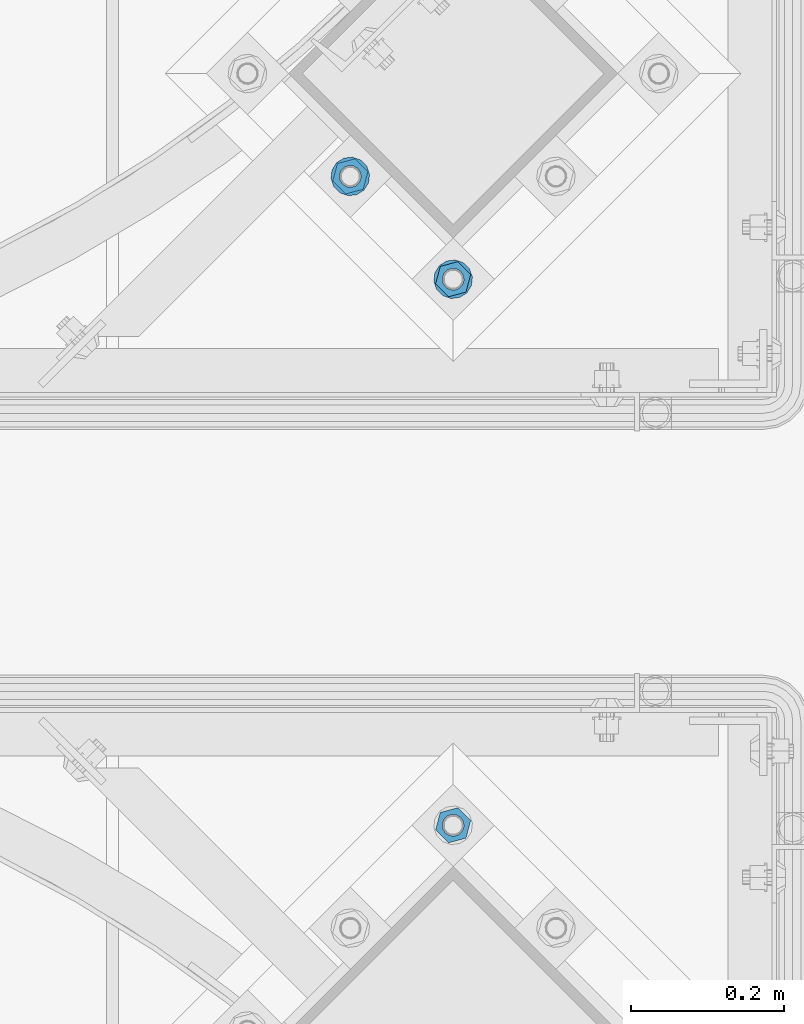
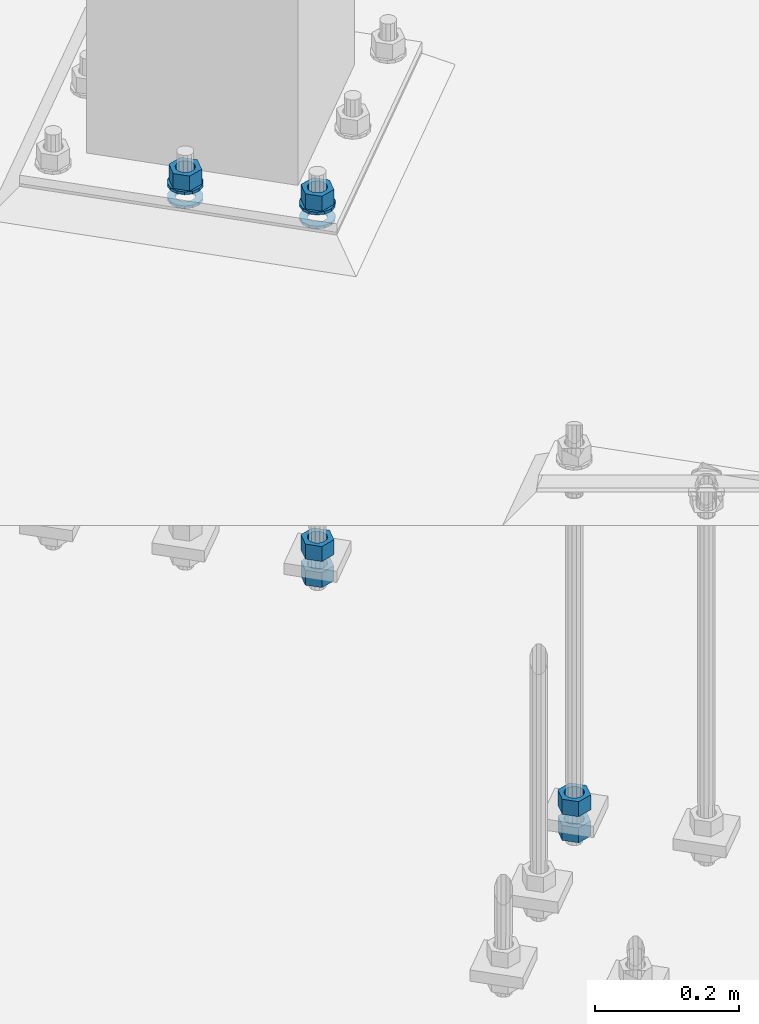
# One storey, part 881 of 1876: 10 columns, 2 elements without a shape of their own.
"""IFC2X3 building model written with IfcOpenShell, lengths in millimetres."""

import ifcopenshell
import ifcopenshell.guid

model = None  # the IFC model being written
_history = None  # IfcOwnerHistory: only IFC2X3 demands one
_inside = {}  # id of a spatial element -> (the spatial element, [elements in it])
_under = {}  # id of a project, library or spatial element -> (it, [spatial elements below it])
_declared = {}  # id of a project -> (the project, [libraries it declares])
_typed = {}  # id of a type object -> (the type object, [elements of that type])
_made_of = {}  # id of a material, layer set ... -> (it, [elements and type objects made of it])


def new_model(schema):
    """Start an empty IFC model of exactly this schema.

    Asked for "IFC4X3", IfcOpenShell would pick the latest addendum, in which some entities
    have other attributes; the version numbers below select the first issue.
    IFC2X3 requires an IfcOwnerHistory on every rooted entity: one is made here for all.
    """
    global model, _history
    if schema == "IFC4X3":
        model = ifcopenshell.file(schema_version=(4, 3, 0, 0))
    else:
        model = ifcopenshell.file(schema=schema)
    _inside.clear()
    _under.clear()
    _declared.clear()
    _typed.clear()
    _made_of.clear()
    _history = None
    if model.schema == "IFC2X3":
        org = make("IfcOrganization", Name="unknown")
        user = make(
            "IfcPersonAndOrganization",
            ThePerson=make("IfcPerson", FamilyName="unknown"),
            TheOrganization=org,
        )
        app = make(
            "IfcApplication",
            ApplicationDeveloper=org,
            Version="unknown",
            ApplicationFullName="unknown",
            ApplicationIdentifier="unknown",
        )
        _history = make(
            "IfcOwnerHistory",
            OwningUser=user,
            OwningApplication=app,
            ChangeAction="ADDED",
            CreationDate=0,
        )
    return model


def make(cls, **values):
    """One entity of the class cls with the attributes given. An attribute that is None is left unset."""
    return model.create_entity(
        cls, **{name: value for name, value in values.items() if value is not None}
    )


def rooted(cls, **values):
    """An entity with a GlobalId (a new one), such as an element, a storey or a relation."""
    return make(cls, GlobalId=ifcopenshell.guid.new(), OwnerHistory=_history, **values)


def si_unit(unit_type, name, prefix=None):
    """IfcSIUnit, for example si_unit("LENGTHUNIT", "METRE", prefix="MILLI")."""
    return make("IfcSIUnit", UnitType=unit_type, Prefix=prefix, Name=name)


def assignment(units):
    """IfcUnitAssignment: the units of a project."""
    return None if units is None else make("IfcUnitAssignment", Units=units)


def point(xyz):
    """IfcCartesianPoint."""
    return None if xyz is None else make("IfcCartesianPoint", Coordinates=xyz)


def direction(xyz):
    """IfcDirection."""
    return None if xyz is None else make("IfcDirection", DirectionRatios=xyz)


def frame(location, z_axis=None, x_axis=None):
    """IfcAxis2Placement3D, a coordinate frame: its origin and axes. An axis left out is left unset."""
    return make(
        "IfcAxis2Placement3D",
        Location=point(location),
        Axis=direction(z_axis),
        RefDirection=direction(x_axis),
    )


def origin_with_axes():
    """The frame at (0, 0, 0) with the z axis (0, 0, 1) and the x axis (1, 0, 0) written out."""
    return frame((0.0, 0.0, 0.0), z_axis=(0.0, 0.0, 1.0), x_axis=(1.0, 0.0, 0.0))


def place(relative_to, where):
    """IfcLocalPlacement: puts the frame where relative to a parent placement (None: the world)."""
    return make(
        "IfcLocalPlacement", PlacementRelTo=relative_to, RelativePlacement=where
    )


def context(
    kind, dimensions, precision=None, world=None, true_north=None, identifier=None
):
    """IfcGeometricRepresentationContext, for example the 3D "Model" context."""
    return make(
        "IfcGeometricRepresentationContext",
        ContextIdentifier=identifier,
        ContextType=kind,
        CoordinateSpaceDimension=dimensions,
        Precision=precision,
        WorldCoordinateSystem=world,
        TrueNorth=true_north,
    )


def subcontext(parent, identifier, kind, view, scale=None):
    """IfcGeometricRepresentationSubContext, for example "Body" below "Model"."""
    return make(
        "IfcGeometricRepresentationSubContext",
        ContextIdentifier=identifier,
        ContextType=kind,
        ParentContext=parent,
        TargetScale=scale,
        TargetView=view,
    )


def project(units=None, contexts=None):
    """IfcProject with its units and contexts."""
    return rooted(
        "IfcProject",
        Name="project",
        RepresentationContexts=contexts,
        UnitsInContext=assignment(units),
    )


def spatial(cls, under=None, at=None, **own):
    """A site, building, storey or space (cls), placed at a placement, below another one or the project."""
    s = rooted(cls, ObjectPlacement=at, **own)
    if under is not None:
        _under.setdefault(under.id(), (under, []))[1].append(s)
    return s


def faces_of(points, faces, orient=None, outer=None):
    """IfcFace entities. A face is a list of loops; a loop is a list of indices into points, from 0.

    orient and outer hold one flag for each loop. By default every Orientation is true, the
    first loop of a face is its IfcFaceOuterBound and the others are IfcFaceBound.
    """
    made = []
    for i, loops in enumerate(faces):
        bounds = []
        for j, loop in enumerate(loops):
            is_outer = j == 0 if outer is None else outer[i][j]
            bounds.append(
                make(
                    "IfcFaceOuterBound" if is_outer else "IfcFaceBound",
                    Bound=make("IfcPolyLoop", Polygon=[points[k] for k in loop]),
                    Orientation=True if orient is None else orient[i][j],
                )
            )
        made.append(make("IfcFace", Bounds=bounds))
    return made


def faceted_brep(points, faces, orient=None, outer=None, voids=None):
    """IfcFacetedBrep: a solid bounded by flat faces; with voids (closed shells), ...WithVoids."""
    shared = [point(p) for p in points]
    hull = make("IfcClosedShell", CfsFaces=faces_of(shared, faces, orient, outer))
    if voids is None:
        return make("IfcFacetedBrep", Outer=hull)
    return make(
        "IfcFacetedBrepWithVoids",
        Outer=hull,
        Voids=[
            make(cls, CfsFaces=faces_of(shared, fs, o, b)) for cls, fs, o, b in voids
        ],
    )


def shape(context_of_items, identifier, shape_type, items):
    """IfcShapeRepresentation: the items that make up one representation, for example the "Body"."""
    return make(
        "IfcShapeRepresentation",
        ContextOfItems=context_of_items,
        RepresentationIdentifier=identifier,
        RepresentationType=shape_type,
        Items=items,
    )


def material(Name=None, Category=None):
    """IfcMaterial."""
    return make("IfcMaterial", Name=Name, Category=Category)


def made_of(thing, what):
    """Note that an element or type object is made of a material, layer set ...; save() writes the relation."""
    if what is not None:
        _made_of.setdefault(what.id(), (what, []))[1].append(thing)
    return thing


def type_object(cls, material=None, **own):
    """A type object (cls), such as IfcWallType, which elements share."""
    return made_of(rooted(cls, **own), material)


def element(
    cls,
    number,
    at=None,
    inside=None,
    cuts=None,
    type_object=None,
    material=None,
    context=None,
    identifier="Body",
    shape_type=None,
    held_by="IfcProductDefinitionShape",
    body=None,
    shapes=None,
    **own,
):
    """One element of the class cls, such as IfcWall. Its Tag is "e" and its number.

    at: its placement. inside: the storey or other place that contains it. cuts: it is an
    opening in that element (IfcRelVoidsElement). A single representation is given by context,
    identifier, shape_type and body (its items); several are given by shapes. held_by: the class
    of the entity that holds the representations. save() writes the other relations.
    """
    e = rooted(cls, Tag="e%d" % number, ObjectPlacement=at, **own)
    if body is not None:
        shapes = [shape(context, identifier, shape_type, body)]
    if shapes is not None:
        e.Representation = make(held_by, Representations=shapes)
    if inside is not None:
        _inside.setdefault(inside.id(), (inside, []))[1].append(e)
    if cuts is not None:
        rooted(
            "IfcRelVoidsElement", RelatingBuildingElement=cuts, RelatedOpeningElement=e
        )
    if type_object is not None:
        _typed.setdefault(type_object.id(), (type_object, []))[1].append(e)
    return made_of(e, material)


def aggregate(whole, parts):
    """IfcRelAggregates: a whole, such as a stair, and the parts it consists of."""
    return rooted("IfcRelAggregates", RelatingObject=whole, RelatedObjects=parts)


def save(model, path):
    """Write the relations noted so far, then the file.

    IfcRelAggregates (storeys below a building ...), IfcRelContainedInSpatialStructure (elements
    in a storey), IfcRelDefinesByType, IfcRelAssociatesMaterial and IfcRelDeclares: one each for
    every whole, place, type object, material and project.
    """
    for whole, parts in _under.values():
        aggregate(whole, parts)
    for where, things in _inside.values():
        rooted(
            "IfcRelContainedInSpatialStructure",
            RelatedElements=things,
            RelatingStructure=where,
        )
    for kind, things in _typed.values():
        rooted("IfcRelDefinesByType", RelatedObjects=things, RelatingType=kind)
    for what, things in _made_of.values():
        rooted("IfcRelAssociatesMaterial", RelatedObjects=things, RelatingMaterial=what)
    for by, libraries in _declared.values():
        rooted("IfcRelDeclares", RelatingContext=by, RelatedDefinitions=libraries)
    model.write(path)


model = new_model("IFC2X3")

# Units and contexts
model_context = context("Model", 3, precision=1e-05, world=origin_with_axes())
body_context = subcontext(model_context, "Body", "Model", "MODEL_VIEW")
ifc_project = project(units=[si_unit("LENGTHUNIT", "METRE", prefix="MILLI"), si_unit("AREAUNIT", "SQUARE_METRE"), si_unit("VOLUMEUNIT", "CUBIC_METRE"), si_unit("MASSUNIT", "GRAM", prefix="KILO"), si_unit("TIMEUNIT", "SECOND"), si_unit("PLANEANGLEUNIT", "RADIAN"), si_unit("SOLIDANGLEUNIT", "STERADIAN"), si_unit("THERMODYNAMICTEMPERATUREUNIT", "DEGREE_CELSIUS"), si_unit("LUMINOUSINTENSITYUNIT", "LUMEN")], contexts=[model_context])

# Site, building, storey
site_placement = place(None, origin_with_axes())
site = spatial("IfcSite", under=ifc_project, at=site_placement, CompositionType="ELEMENT")
building_placement = place(site_placement, origin_with_axes())
building = spatial("IfcBuilding", under=site, at=building_placement, Name="Undefined", CompositionType="ELEMENT")
storey_placement = place(building_placement, origin_with_axes())
storey = spatial("IfcBuildingStorey", under=building, at=storey_placement, Name="Undefined", CompositionType="ELEMENT", Elevation=0.0)

# Assembly, columns
assembly_1_placement = place(storey_placement, origin_with_axes())
assembly_1 = element("IfcElementAssembly", 1, at=assembly_1_placement, inside=storey, Name="TEMPLATE", AssemblyPlace="NOTDEFINED", PredefinedType="RIGID_FRAME")
ifc_material_1 = material(Name="STEEL/A563")
column_type_1 = type_object("IfcColumnType", Name="1_HEAVY_HEX_NUT", PredefinedType="NOTDEFINED")
column_1_placement = place(assembly_1_placement, frame((6580.27489085662, -11920.9174255113, -508.0), z_axis=(-0.707106781186547, -0.707106781186548, 0.0), x_axis=(0.0, 0.0, -1.0)))
column_1 = element("IfcColumn", 2, at=column_1_placement, type_object=column_type_1, material=ifc_material_1, Name="NUT", ObjectType="1_HEAVY_HEX_NUT", context=body_context, shape_type="Brep", body=[
    faceted_brep([(0.0, -23.8099994659442, 9.09494701772928e-13), (0.0, -11.9099998474121, -20.6200008392352), (25.4, -11.9099998474157, -20.6200008392361), (25.4, -23.8099994659478, 0.0), (0.0, 11.9099998474157, -20.620000839237), (25.4, 11.9099998474121, -20.620000839237), (0.0, 23.8099994659478, 9.09494701772928e-13), (25.4, 23.8099994659442, 0.0), (0.0, 11.9099998474157, 20.620000839237), (25.4, 11.9099998474121, 20.620000839237), (0.0, -11.9099998474121, 20.6200008392389), (25.4, -11.9099998474157, 20.6200008392379), (0.0, 1.81898940354586e-12, 14.2899999618567), (0.0, 6.20019861543915, 12.8748450879584), (25.4, 6.20019861543733, 12.8748450879593), (25.4, 0.0, 14.2899999618558), (0.0, 11.1723718546473, 8.90966924477925), (25.4, 11.1723718546436, 8.90966924477925), (0.0, 13.9317198278914, 3.17982413774916), (25.4, 13.9317198278877, 3.17982413775007), (0.0, 13.9317198278914, -3.17982413774644), (25.4, 13.9317198278895, -3.17982413774735), (0.0, 11.1723718546473, -8.90966924477834), (25.4, 11.1723718546455, -8.90966924477925), (0.0, 6.20019861544279, -12.8748450879575), (25.4, 6.20019861543915, -12.8748450879584), (0.0, 3.63797880709171e-12, -14.2899999618548), (25.4, -3.63797880709171e-12, -14.2899999618548), (0.0, -6.20019861543733, -12.8748450879566), (25.4, -6.20019861544097, -12.8748450879584), (0.0, -11.1723718546455, -8.90966924477743), (25.4, -11.1723718546473, -8.90966924477834), (0.0, -13.9317198278877, -3.17982413774735), (25.4, -13.9317198278914, -3.17982413774826), (0.0, -13.9317198278895, 3.17982413774735), (25.4, -13.9317198278914, 3.17982413774826), (0.0, -11.1723718546455, 8.90966924477925), (25.4, -11.1723718546473, 8.90966924478016), (0.0, -6.20019861543915, 12.8748450879593), (25.4, -6.20019861544279, 12.8748450879593)], [[[0, 1, 2, 3]], [[1, 4, 5, 2]], [[4, 6, 7, 5]], [[6, 8, 9, 7]], [[8, 10, 11, 9]], [[10, 0, 3, 11]], [[12, 13, 14, 15]], [[13, 16, 17, 14]], [[16, 18, 19, 17]], [[18, 20, 21, 19]], [[20, 22, 23, 21]], [[22, 24, 25, 23]], [[24, 26, 27, 25]], [[26, 28, 29, 27]], [[28, 30, 31, 29]], [[30, 32, 33, 31]], [[32, 34, 35, 33]], [[34, 36, 37, 35]], [[36, 38, 39, 37]], [[38, 12, 15, 39]], [[5, 7, 9, 11, 3, 2], [17, 19, 21, 23, 25, 27, 29, 31, 33, 35, 37, 39, 15, 14]], [[10, 8, 6, 4, 1, 0], [38, 36, 34, 32, 30, 28, 26, 24, 22, 20, 18, 16, 13, 12]]]),
])
column_2_placement = place(assembly_1_placement, frame((6580.27489085662, -11920.9174255113, -552.45), z_axis=(-0.707106781186547, -0.707106781186548, 0.0), x_axis=(0.0, 0.0, -1.0)))
column_2 = element("IfcColumn", 3, at=column_2_placement, type_object=column_type_1, material=ifc_material_1, Name="NUT", ObjectType="1_HEAVY_HEX_NUT", context=body_context, shape_type="Brep", body=[
    faceted_brep([(0.0, -23.8099994659442, 9.09494701772928e-13), (0.0, -11.9099998474121, -20.6200008392352), (25.4, -11.9099998474157, -20.6200008392361), (25.4, -23.8099994659478, 0.0), (0.0, 11.9099998474157, -20.620000839237), (25.4, 11.9099998474121, -20.620000839237), (0.0, 23.8099994659478, 9.09494701772928e-13), (25.4, 23.8099994659442, 0.0), (0.0, 11.9099998474157, 20.620000839237), (25.4, 11.9099998474121, 20.620000839237), (0.0, -11.9099998474121, 20.6200008392389), (25.4, -11.9099998474157, 20.6200008392379), (0.0, 1.81898940354586e-12, 14.2899999618567), (0.0, 6.20019861543915, 12.8748450879584), (25.4, 6.20019861543733, 12.8748450879593), (25.4, 0.0, 14.2899999618558), (0.0, 11.1723718546473, 8.90966924477925), (25.4, 11.1723718546436, 8.90966924477925), (0.0, 13.9317198278914, 3.17982413774916), (25.4, 13.9317198278877, 3.17982413775007), (0.0, 13.9317198278914, -3.17982413774644), (25.4, 13.9317198278895, -3.17982413774735), (0.0, 11.1723718546473, -8.90966924477834), (25.4, 11.1723718546455, -8.90966924477925), (0.0, 6.20019861544279, -12.8748450879575), (25.4, 6.20019861543915, -12.8748450879584), (0.0, 3.63797880709171e-12, -14.2899999618548), (25.4, -3.63797880709171e-12, -14.2899999618548), (0.0, -6.20019861543733, -12.8748450879566), (25.4, -6.20019861544097, -12.8748450879584), (0.0, -11.1723718546455, -8.90966924477743), (25.4, -11.1723718546473, -8.90966924477834), (0.0, -13.9317198278877, -3.17982413774735), (25.4, -13.9317198278914, -3.17982413774826), (0.0, -13.9317198278895, 3.17982413774735), (25.4, -13.9317198278914, 3.17982413774826), (0.0, -11.1723718546455, 8.90966924477925), (25.4, -11.1723718546473, 8.90966924478016), (0.0, -6.20019861543915, 12.8748450879593), (25.4, -6.20019861544279, 12.8748450879593)], [[[0, 1, 2, 3]], [[1, 4, 5, 2]], [[4, 6, 7, 5]], [[6, 8, 9, 7]], [[8, 10, 11, 9]], [[10, 0, 3, 11]], [[12, 13, 14, 15]], [[13, 16, 17, 14]], [[16, 18, 19, 17]], [[18, 20, 21, 19]], [[20, 22, 23, 21]], [[22, 24, 25, 23]], [[24, 26, 27, 25]], [[26, 28, 29, 27]], [[28, 30, 31, 29]], [[30, 32, 33, 31]], [[32, 34, 35, 33]], [[34, 36, 37, 35]], [[36, 38, 39, 37]], [[38, 12, 15, 39]], [[5, 7, 9, 11, 3, 2], [17, 19, 21, 23, 25, 27, 29, 31, 33, 35, 37, 39, 15, 14]], [[10, 8, 6, 4, 1, 0], [38, 36, 34, 32, 30, 28, 26, 24, 22, 20, 18, 16, 13, 12]]]),
])
aggregate(assembly_1, [column_1, column_2])

assembly_2_placement = place(storey_placement, origin_with_axes())
assembly_2 = element("IfcElementAssembly", 4, at=assembly_2_placement, inside=storey, Name="TEMPLATE", AssemblyPlace="NOTDEFINED", PredefinedType="RIGID_FRAME")
column_3_placement = place(assembly_2_placement, frame((6580.27820529301, -11205.6400740426, 87.3125), z_axis=(0.707106781186548, 0.707106781186547, 0.0), x_axis=(0.0, 0.0, -1.0)))
column_3 = element("IfcColumn", 5, at=column_3_placement, type_object=column_type_1, material=ifc_material_1, Name="NUT", ObjectType="1_HEAVY_HEX_NUT", context=body_context, shape_type="Brep", body=[
    faceted_brep([(0.0, -23.8099994659442, 9.09494701772928e-13), (0.0, -11.9099998474121, -20.6200008392352), (25.4, -11.9099998474157, -20.6200008392361), (25.4, -23.8099994659478, 0.0), (0.0, 11.9099998474157, -20.620000839237), (25.4, 11.9099998474121, -20.620000839237), (0.0, 23.8099994659478, 9.09494701772928e-13), (25.4, 23.8099994659442, 0.0), (0.0, 11.9099998474157, 20.620000839237), (25.4, 11.9099998474121, 20.620000839237), (0.0, -11.9099998474121, 20.6200008392389), (25.4, -11.9099998474157, 20.6200008392379), (0.0, 1.81898940354586e-12, 14.2899999618567), (0.0, 6.20019861543915, 12.8748450879584), (25.4, 6.20019861543733, 12.8748450879593), (25.4, 0.0, 14.2899999618558), (0.0, 11.1723718546473, 8.90966924477925), (25.4, 11.1723718546436, 8.90966924477925), (0.0, 13.9317198278914, 3.17982413774916), (25.4, 13.9317198278877, 3.17982413775007), (0.0, 13.9317198278914, -3.17982413774644), (25.4, 13.9317198278895, -3.17982413774735), (0.0, 11.1723718546473, -8.90966924477834), (25.4, 11.1723718546455, -8.90966924477925), (0.0, 6.20019861544279, -12.8748450879575), (25.4, 6.20019861543915, -12.8748450879584), (0.0, 3.63797880709171e-12, -14.2899999618548), (25.4, -3.63797880709171e-12, -14.2899999618548), (0.0, -6.20019861543733, -12.8748450879566), (25.4, -6.20019861544097, -12.8748450879584), (0.0, -11.1723718546455, -8.90966924477743), (25.4, -11.1723718546473, -8.90966924477834), (0.0, -13.9317198278877, -3.17982413774735), (25.4, -13.9317198278914, -3.17982413774826), (0.0, -13.9317198278895, 3.17982413774735), (25.4, -13.9317198278914, 3.17982413774826), (0.0, -11.1723718546455, 8.90966924477925), (25.4, -11.1723718546473, 8.90966924478016), (0.0, -6.20019861543915, 12.8748450879593), (25.4, -6.20019861544279, 12.8748450879593)], [[[0, 1, 2, 3]], [[1, 4, 5, 2]], [[4, 6, 7, 5]], [[6, 8, 9, 7]], [[8, 10, 11, 9]], [[10, 0, 3, 11]], [[12, 13, 14, 15]], [[13, 16, 17, 14]], [[16, 18, 19, 17]], [[18, 20, 21, 19]], [[20, 22, 23, 21]], [[22, 24, 25, 23]], [[24, 26, 27, 25]], [[26, 28, 29, 27]], [[28, 30, 31, 29]], [[30, 32, 33, 31]], [[32, 34, 35, 33]], [[34, 36, 37, 35]], [[36, 38, 39, 37]], [[38, 12, 15, 39]], [[5, 7, 9, 11, 3, 2], [17, 19, 21, 23, 25, 27, 29, 31, 33, 35, 37, 39, 15, 14]], [[10, 8, 6, 4, 1, 0], [38, 36, 34, 32, 30, 28, 26, 24, 22, 20, 18, 16, 13, 12]]]),
])
column_4_placement = place(assembly_2_placement, frame((6580.27820529301, -11205.6400740426, -508.0), z_axis=(0.707106781186548, 0.707106781186547, 0.0), x_axis=(0.0, 0.0, -1.0)))
column_4 = element("IfcColumn", 6, at=column_4_placement, type_object=column_type_1, material=ifc_material_1, Name="NUT", ObjectType="1_HEAVY_HEX_NUT", context=body_context, shape_type="Brep", body=[
    faceted_brep([(0.0, -23.8099994659442, 9.09494701772928e-13), (0.0, -11.9099998474121, -20.6200008392352), (25.4, -11.9099998474157, -20.6200008392361), (25.4, -23.8099994659478, 0.0), (0.0, 11.9099998474157, -20.620000839237), (25.4, 11.9099998474121, -20.620000839237), (0.0, 23.8099994659478, 9.09494701772928e-13), (25.4, 23.8099994659442, 0.0), (0.0, 11.9099998474157, 20.620000839237), (25.4, 11.9099998474121, 20.620000839237), (0.0, -11.9099998474121, 20.6200008392389), (25.4, -11.9099998474157, 20.6200008392379), (0.0, 1.81898940354586e-12, 14.2899999618567), (0.0, 6.20019861543915, 12.8748450879584), (25.4, 6.20019861543733, 12.8748450879593), (25.4, 0.0, 14.2899999618558), (0.0, 11.1723718546473, 8.90966924477925), (25.4, 11.1723718546436, 8.90966924477925), (0.0, 13.9317198278914, 3.17982413774916), (25.4, 13.9317198278877, 3.17982413775007), (0.0, 13.9317198278914, -3.17982413774644), (25.4, 13.9317198278895, -3.17982413774735), (0.0, 11.1723718546473, -8.90966924477834), (25.4, 11.1723718546455, -8.90966924477925), (0.0, 6.20019861544279, -12.8748450879575), (25.4, 6.20019861543915, -12.8748450879584), (0.0, 3.63797880709171e-12, -14.2899999618548), (25.4, -3.63797880709171e-12, -14.2899999618548), (0.0, -6.20019861543733, -12.8748450879566), (25.4, -6.20019861544097, -12.8748450879584), (0.0, -11.1723718546455, -8.90966924477743), (25.4, -11.1723718546473, -8.90966924477834), (0.0, -13.9317198278877, -3.17982413774735), (25.4, -13.9317198278914, -3.17982413774826), (0.0, -13.9317198278895, 3.17982413774735), (25.4, -13.9317198278914, 3.17982413774826), (0.0, -11.1723718546455, 8.90966924477925), (25.4, -11.1723718546473, 8.90966924478016), (0.0, -6.20019861543915, 12.8748450879593), (25.4, -6.20019861544279, 12.8748450879593)], [[[0, 1, 2, 3]], [[1, 4, 5, 2]], [[4, 6, 7, 5]], [[6, 8, 9, 7]], [[8, 10, 11, 9]], [[10, 0, 3, 11]], [[12, 13, 14, 15]], [[13, 16, 17, 14]], [[16, 18, 19, 17]], [[18, 20, 21, 19]], [[20, 22, 23, 21]], [[22, 24, 25, 23]], [[24, 26, 27, 25]], [[26, 28, 29, 27]], [[28, 30, 31, 29]], [[30, 32, 33, 31]], [[32, 34, 35, 33]], [[34, 36, 37, 35]], [[36, 38, 39, 37]], [[38, 12, 15, 39]], [[5, 7, 9, 11, 3, 2], [17, 19, 21, 23, 25, 27, 29, 31, 33, 35, 37, 39, 15, 14]], [[10, 8, 6, 4, 1, 0], [38, 36, 34, 32, 30, 28, 26, 24, 22, 20, 18, 16, 13, 12]]]),
])
column_5_placement = place(assembly_2_placement, frame((6580.27820529301, -11205.6400740426, -552.45), z_axis=(0.707106781186548, 0.707106781186547, 0.0), x_axis=(0.0, 0.0, -1.0)))
column_5 = element("IfcColumn", 7, at=column_5_placement, type_object=column_type_1, material=ifc_material_1, Name="NUT", ObjectType="1_HEAVY_HEX_NUT", context=body_context, shape_type="Brep", body=[
    faceted_brep([(0.0, -23.8099994659442, 9.09494701772928e-13), (0.0, -11.9099998474121, -20.6200008392352), (25.4, -11.9099998474157, -20.6200008392361), (25.4, -23.8099994659478, 0.0), (0.0, 11.9099998474157, -20.620000839237), (25.4, 11.9099998474121, -20.620000839237), (0.0, 23.8099994659478, 9.09494701772928e-13), (25.4, 23.8099994659442, 0.0), (0.0, 11.9099998474157, 20.620000839237), (25.4, 11.9099998474121, 20.620000839237), (0.0, -11.9099998474121, 20.6200008392389), (25.4, -11.9099998474157, 20.6200008392379), (0.0, 1.81898940354586e-12, 14.2899999618567), (0.0, 6.20019861543915, 12.8748450879584), (25.4, 6.20019861543733, 12.8748450879593), (25.4, 0.0, 14.2899999618558), (0.0, 11.1723718546473, 8.90966924477925), (25.4, 11.1723718546436, 8.90966924477925), (0.0, 13.9317198278914, 3.17982413774916), (25.4, 13.9317198278877, 3.17982413775007), (0.0, 13.9317198278914, -3.17982413774644), (25.4, 13.9317198278895, -3.17982413774735), (0.0, 11.1723718546473, -8.90966924477834), (25.4, 11.1723718546455, -8.90966924477925), (0.0, 6.20019861544279, -12.8748450879575), (25.4, 6.20019861543915, -12.8748450879584), (0.0, 3.63797880709171e-12, -14.2899999618548), (25.4, -3.63797880709171e-12, -14.2899999618548), (0.0, -6.20019861543733, -12.8748450879566), (25.4, -6.20019861544097, -12.8748450879584), (0.0, -11.1723718546455, -8.90966924477743), (25.4, -11.1723718546473, -8.90966924477834), (0.0, -13.9317198278877, -3.17982413774735), (25.4, -13.9317198278914, -3.17982413774826), (0.0, -13.9317198278895, 3.17982413774735), (25.4, -13.9317198278914, 3.17982413774826), (0.0, -11.1723718546455, 8.90966924477925), (25.4, -11.1723718546473, 8.90966924478016), (0.0, -6.20019861543915, 12.8748450879593), (25.4, -6.20019861544279, 12.8748450879593)], [[[0, 1, 2, 3]], [[1, 4, 5, 2]], [[4, 6, 7, 5]], [[6, 8, 9, 7]], [[8, 10, 11, 9]], [[10, 0, 3, 11]], [[12, 13, 14, 15]], [[13, 16, 17, 14]], [[16, 18, 19, 17]], [[18, 20, 21, 19]], [[20, 22, 23, 21]], [[22, 24, 25, 23]], [[24, 26, 27, 25]], [[26, 28, 29, 27]], [[28, 30, 31, 29]], [[30, 32, 33, 31]], [[32, 34, 35, 33]], [[34, 36, 37, 35]], [[36, 38, 39, 37]], [[38, 12, 15, 39]], [[5, 7, 9, 11, 3, 2], [17, 19, 21, 23, 25, 27, 29, 31, 33, 35, 37, 39, 15, 14]], [[10, 8, 6, 4, 1, 0], [38, 36, 34, 32, 30, 28, 26, 24, 22, 20, 18, 16, 13, 12]]]),
])
column_6_placement = place(assembly_2_placement, frame((6445.57436347686, -11070.9362322265, 87.3125), z_axis=(0.707106781186548, 0.707106781186547, 0.0), x_axis=(0.0, 0.0, -1.0)))
column_6 = element("IfcColumn", 8, at=column_6_placement, type_object=column_type_1, material=ifc_material_1, Name="NUT", ObjectType="1_HEAVY_HEX_NUT", context=body_context, shape_type="Brep", body=[
    faceted_brep([(0.0, -23.8099994659442, 9.09494701772928e-13), (0.0, -11.9099998474121, -20.6200008392352), (25.4, -11.9099998474157, -20.6200008392361), (25.4, -23.8099994659478, 0.0), (0.0, 11.9099998474157, -20.620000839237), (25.4, 11.9099998474121, -20.620000839237), (0.0, 23.8099994659478, 9.09494701772928e-13), (25.4, 23.8099994659442, 0.0), (0.0, 11.9099998474157, 20.620000839237), (25.4, 11.9099998474121, 20.620000839237), (0.0, -11.9099998474121, 20.6200008392389), (25.4, -11.9099998474157, 20.6200008392379), (0.0, 1.81898940354586e-12, 14.2899999618567), (0.0, 6.20019861543915, 12.8748450879584), (25.4, 6.20019861543733, 12.8748450879593), (25.4, 0.0, 14.2899999618558), (0.0, 11.1723718546473, 8.90966924477925), (25.4, 11.1723718546436, 8.90966924477925), (0.0, 13.9317198278914, 3.17982413774916), (25.4, 13.9317198278877, 3.17982413775007), (0.0, 13.9317198278914, -3.17982413774644), (25.4, 13.9317198278895, -3.17982413774735), (0.0, 11.1723718546473, -8.90966924477834), (25.4, 11.1723718546455, -8.90966924477925), (0.0, 6.20019861544279, -12.8748450879575), (25.4, 6.20019861543915, -12.8748450879584), (0.0, 3.63797880709171e-12, -14.2899999618548), (25.4, -3.63797880709171e-12, -14.2899999618548), (0.0, -6.20019861543733, -12.8748450879566), (25.4, -6.20019861544097, -12.8748450879584), (0.0, -11.1723718546455, -8.90966924477743), (25.4, -11.1723718546473, -8.90966924477834), (0.0, -13.9317198278877, -3.17982413774735), (25.4, -13.9317198278914, -3.17982413774826), (0.0, -13.9317198278895, 3.17982413774735), (25.4, -13.9317198278914, 3.17982413774826), (0.0, -11.1723718546455, 8.90966924477925), (25.4, -11.1723718546473, 8.90966924478016), (0.0, -6.20019861543915, 12.8748450879593), (25.4, -6.20019861544279, 12.8748450879593)], [[[0, 1, 2, 3]], [[1, 4, 5, 2]], [[4, 6, 7, 5]], [[6, 8, 9, 7]], [[8, 10, 11, 9]], [[10, 0, 3, 11]], [[12, 13, 14, 15]], [[13, 16, 17, 14]], [[16, 18, 19, 17]], [[18, 20, 21, 19]], [[20, 22, 23, 21]], [[22, 24, 25, 23]], [[24, 26, 27, 25]], [[26, 28, 29, 27]], [[28, 30, 31, 29]], [[30, 32, 33, 31]], [[32, 34, 35, 33]], [[34, 36, 37, 35]], [[36, 38, 39, 37]], [[38, 12, 15, 39]], [[5, 7, 9, 11, 3, 2], [17, 19, 21, 23, 25, 27, 29, 31, 33, 35, 37, 39, 15, 14]], [[10, 8, 6, 4, 1, 0], [38, 36, 34, 32, 30, 28, 26, 24, 22, 20, 18, 16, 13, 12]]]),
])
ifc_material_2 = material(Name="STEEL/F436")
column_type_2 = type_object("IfcColumnType", Name="1_WASHER", PredefinedType="NOTDEFINED")
column_7_placement = place(assembly_2_placement, frame((6580.27820529301, -11205.6400740426, 38.1), z_axis=(0.707106781186548, 0.707106781186547, 0.0), x_axis=(0.0, 0.0, -1.0)))
column_7 = element("IfcColumn", 9, at=column_7_placement, type_object=column_type_2, material=ifc_material_2, Name="WASHER", ObjectType="1_WASHER", context=body_context, shape_type="Brep", body=[
    faceted_brep([(0.0, -25.3999996185375, 0.0), (0.0, -22.8846089010331, -11.0206468080742), (4.7625, -22.8846089010331, -11.0206468080742), (4.7625, -25.3999996185375, 0.0), (0.0, -15.8366407293743, -19.8585193564477), (4.7625, -15.8366407293743, -19.8585193564477), (0.0, -5.65203163760816, -24.7631685975166), (4.7625, -5.65203163760816, -24.7631685975166), (0.0, 5.65203163760452, -24.7631685975166), (4.7625, 5.65203163760452, -24.7631685975166), (0.0, 15.8366407293706, -19.858519356445), (4.7625, 15.8366407293706, -19.858519356445), (0.0, 22.8846089010331, -11.0206468080733), (4.7625, 22.8846089010331, -11.0206468080733), (0.0, 25.3999996185339, 9.09494701772928e-13), (4.7625, 25.3999996185339, 9.09494701772928e-13), (0.0, 22.8846089010331, 11.0206468080751), (4.7625, 22.8846089010331, 11.0206468080751), (0.0, 15.8366407293706, 19.8585193564486), (4.7625, 15.8366407293706, 19.8585193564486), (0.0, 5.65203163760452, 24.7631685975175), (4.7625, 5.65203163760452, 24.7631685975175), (0.0, -5.65203163760816, 24.7631685975175), (4.7625, -5.65203163760816, 24.7631685975175), (0.0, -15.8366407293724, 19.8585193564459), (4.7625, -15.8366407293724, 19.8585193564459), (0.0, -22.8846089010367, 11.0206468080751), (4.7625, -22.8846089010367, 11.0206468080751), (0.0, 1.81898940354586e-12, 14.2899999618567), (0.0, 6.20019861543915, 12.8748450879584), (4.7625, 6.20019861543733, 12.8748450879593), (4.7625, 0.0, 14.2899999618558), (0.0, 11.1723718546473, 8.90966924477925), (4.7625, 11.1723718546436, 8.90966924477925), (0.0, 13.9317198278914, 3.17982413774916), (4.7625, 13.9317198278877, 3.17982413775007), (0.0, 13.9317198278914, -3.17982413774644), (4.7625, 13.9317198278895, -3.17982413774735), (0.0, 11.1723718546473, -8.90966924477834), (4.7625, 11.1723718546455, -8.90966924477925), (0.0, 6.20019861544279, -12.8748450879575), (4.7625, 6.20019861543915, -12.8748450879584), (0.0, 3.63797880709171e-12, -14.2899999618548), (4.7625, -3.63797880709171e-12, -14.2899999618548), (0.0, -6.20019861543733, -12.8748450879566), (4.7625, -6.20019861544097, -12.8748450879584), (0.0, -11.1723718546455, -8.90966924477743), (4.7625, -11.1723718546473, -8.90966924477834), (0.0, -13.9317198278877, -3.17982413774735), (4.7625, -13.9317198278914, -3.17982413774826), (0.0, -13.9317198278895, 3.17982413774735), (4.7625, -13.9317198278914, 3.17982413774826), (0.0, -11.1723718546455, 8.90966924477925), (4.7625, -11.1723718546473, 8.90966924478016), (0.0, -6.20019861543915, 12.8748450879593), (4.7625, -6.20019861544279, 12.8748450879593)], [[[0, 1, 2, 3]], [[1, 4, 5, 2]], [[4, 6, 7, 5]], [[6, 8, 9, 7]], [[8, 10, 11, 9]], [[10, 12, 13, 11]], [[12, 14, 15, 13]], [[14, 16, 17, 15]], [[16, 18, 19, 17]], [[18, 20, 21, 19]], [[20, 22, 23, 21]], [[22, 24, 25, 23]], [[24, 26, 27, 25]], [[26, 0, 3, 27]], [[28, 29, 30, 31]], [[29, 32, 33, 30]], [[32, 34, 35, 33]], [[34, 36, 37, 35]], [[36, 38, 39, 37]], [[38, 40, 41, 39]], [[40, 42, 43, 41]], [[42, 44, 45, 43]], [[44, 46, 47, 45]], [[46, 48, 49, 47]], [[48, 50, 51, 49]], [[50, 52, 53, 51]], [[52, 54, 55, 53]], [[54, 28, 31, 55]], [[5, 7, 9, 11, 13, 15, 17, 19, 21, 23, 25, 27, 3, 2], [33, 35, 37, 39, 41, 43, 45, 47, 49, 51, 53, 55, 31, 30]], [[26, 24, 22, 20, 18, 16, 14, 12, 10, 8, 6, 4, 1, 0], [54, 52, 50, 48, 46, 44, 42, 40, 38, 36, 34, 32, 29, 28]]]),
])
column_8_placement = place(assembly_2_placement, frame((6580.27820529301, -11205.6400740426, 61.9125), z_axis=(0.707106781186548, 0.707106781186547, 0.0), x_axis=(0.0, 0.0, -1.0)))
column_8 = element("IfcColumn", 10, at=column_8_placement, type_object=column_type_2, material=ifc_material_2, Name="WASHER", ObjectType="1_WASHER", context=body_context, shape_type="Brep", body=[
    faceted_brep([(0.0, -25.3999996185375, 0.0), (0.0, -22.8846089010331, -11.0206468080742), (4.7625, -22.8846089010331, -11.0206468080742), (4.7625, -25.3999996185375, 0.0), (0.0, -15.8366407293743, -19.8585193564477), (4.7625, -15.8366407293743, -19.8585193564477), (0.0, -5.65203163760816, -24.7631685975166), (4.7625, -5.65203163760816, -24.7631685975166), (0.0, 5.65203163760452, -24.7631685975166), (4.7625, 5.65203163760452, -24.7631685975166), (0.0, 15.8366407293706, -19.858519356445), (4.7625, 15.8366407293706, -19.858519356445), (0.0, 22.8846089010331, -11.0206468080733), (4.7625, 22.8846089010331, -11.0206468080733), (0.0, 25.3999996185339, 9.09494701772928e-13), (4.7625, 25.3999996185339, 9.09494701772928e-13), (0.0, 22.8846089010331, 11.0206468080751), (4.7625, 22.8846089010331, 11.0206468080751), (0.0, 15.8366407293706, 19.8585193564486), (4.7625, 15.8366407293706, 19.8585193564486), (0.0, 5.65203163760452, 24.7631685975175), (4.7625, 5.65203163760452, 24.7631685975175), (0.0, -5.65203163760816, 24.7631685975175), (4.7625, -5.65203163760816, 24.7631685975175), (0.0, -15.8366407293724, 19.8585193564459), (4.7625, -15.8366407293724, 19.8585193564459), (0.0, -22.8846089010367, 11.0206468080751), (4.7625, -22.8846089010367, 11.0206468080751), (0.0, 1.81898940354586e-12, 14.2899999618567), (0.0, 6.20019861543915, 12.8748450879584), (4.7625, 6.20019861543733, 12.8748450879593), (4.7625, 0.0, 14.2899999618558), (0.0, 11.1723718546473, 8.90966924477925), (4.7625, 11.1723718546436, 8.90966924477925), (0.0, 13.9317198278914, 3.17982413774916), (4.7625, 13.9317198278877, 3.17982413775007), (0.0, 13.9317198278914, -3.17982413774644), (4.7625, 13.9317198278895, -3.17982413774735), (0.0, 11.1723718546473, -8.90966924477834), (4.7625, 11.1723718546455, -8.90966924477925), (0.0, 6.20019861544279, -12.8748450879575), (4.7625, 6.20019861543915, -12.8748450879584), (0.0, 3.63797880709171e-12, -14.2899999618548), (4.7625, -3.63797880709171e-12, -14.2899999618548), (0.0, -6.20019861543733, -12.8748450879566), (4.7625, -6.20019861544097, -12.8748450879584), (0.0, -11.1723718546455, -8.90966924477743), (4.7625, -11.1723718546473, -8.90966924477834), (0.0, -13.9317198278877, -3.17982413774735), (4.7625, -13.9317198278914, -3.17982413774826), (0.0, -13.9317198278895, 3.17982413774735), (4.7625, -13.9317198278914, 3.17982413774826), (0.0, -11.1723718546455, 8.90966924477925), (4.7625, -11.1723718546473, 8.90966924478016), (0.0, -6.20019861543915, 12.8748450879593), (4.7625, -6.20019861544279, 12.8748450879593)], [[[0, 1, 2, 3]], [[1, 4, 5, 2]], [[4, 6, 7, 5]], [[6, 8, 9, 7]], [[8, 10, 11, 9]], [[10, 12, 13, 11]], [[12, 14, 15, 13]], [[14, 16, 17, 15]], [[16, 18, 19, 17]], [[18, 20, 21, 19]], [[20, 22, 23, 21]], [[22, 24, 25, 23]], [[24, 26, 27, 25]], [[26, 0, 3, 27]], [[28, 29, 30, 31]], [[29, 32, 33, 30]], [[32, 34, 35, 33]], [[34, 36, 37, 35]], [[36, 38, 39, 37]], [[38, 40, 41, 39]], [[40, 42, 43, 41]], [[42, 44, 45, 43]], [[44, 46, 47, 45]], [[46, 48, 49, 47]], [[48, 50, 51, 49]], [[50, 52, 53, 51]], [[52, 54, 55, 53]], [[54, 28, 31, 55]], [[5, 7, 9, 11, 13, 15, 17, 19, 21, 23, 25, 27, 3, 2], [33, 35, 37, 39, 41, 43, 45, 47, 49, 51, 53, 55, 31, 30]], [[26, 24, 22, 20, 18, 16, 14, 12, 10, 8, 6, 4, 1, 0], [54, 52, 50, 48, 46, 44, 42, 40, 38, 36, 34, 32, 29, 28]]]),
])
column_9_placement = place(assembly_2_placement, frame((6445.57436347686, -11070.9362322265, 38.1), z_axis=(0.707106781186548, 0.707106781186547, 0.0), x_axis=(0.0, 0.0, -1.0)))
column_9 = element("IfcColumn", 11, at=column_9_placement, type_object=column_type_2, material=ifc_material_2, Name="WASHER", ObjectType="1_WASHER", context=body_context, shape_type="Brep", body=[
    faceted_brep([(0.0, -25.3999996185375, 0.0), (0.0, -22.8846089010331, -11.0206468080742), (4.7625, -22.8846089010331, -11.0206468080742), (4.7625, -25.3999996185375, 0.0), (0.0, -15.8366407293743, -19.8585193564477), (4.7625, -15.8366407293743, -19.8585193564477), (0.0, -5.65203163760816, -24.7631685975166), (4.7625, -5.65203163760816, -24.7631685975166), (0.0, 5.65203163760452, -24.7631685975166), (4.7625, 5.65203163760452, -24.7631685975166), (0.0, 15.8366407293706, -19.858519356445), (4.7625, 15.8366407293706, -19.858519356445), (0.0, 22.8846089010331, -11.0206468080733), (4.7625, 22.8846089010331, -11.0206468080733), (0.0, 25.3999996185339, 9.09494701772928e-13), (4.7625, 25.3999996185339, 9.09494701772928e-13), (0.0, 22.8846089010331, 11.0206468080751), (4.7625, 22.8846089010331, 11.0206468080751), (0.0, 15.8366407293706, 19.8585193564486), (4.7625, 15.8366407293706, 19.8585193564486), (0.0, 5.65203163760452, 24.7631685975175), (4.7625, 5.65203163760452, 24.7631685975175), (0.0, -5.65203163760816, 24.7631685975175), (4.7625, -5.65203163760816, 24.7631685975175), (0.0, -15.8366407293724, 19.8585193564459), (4.7625, -15.8366407293724, 19.8585193564459), (0.0, -22.8846089010367, 11.0206468080751), (4.7625, -22.8846089010367, 11.0206468080751), (0.0, 1.81898940354586e-12, 14.2899999618567), (0.0, 6.20019861543915, 12.8748450879584), (4.7625, 6.20019861543733, 12.8748450879593), (4.7625, 0.0, 14.2899999618558), (0.0, 11.1723718546473, 8.90966924477925), (4.7625, 11.1723718546436, 8.90966924477925), (0.0, 13.9317198278914, 3.17982413774916), (4.7625, 13.9317198278877, 3.17982413775007), (0.0, 13.9317198278914, -3.17982413774644), (4.7625, 13.9317198278895, -3.17982413774735), (0.0, 11.1723718546473, -8.90966924477834), (4.7625, 11.1723718546455, -8.90966924477925), (0.0, 6.20019861544279, -12.8748450879575), (4.7625, 6.20019861543915, -12.8748450879584), (0.0, 3.63797880709171e-12, -14.2899999618548), (4.7625, -3.63797880709171e-12, -14.2899999618548), (0.0, -6.20019861543733, -12.8748450879566), (4.7625, -6.20019861544097, -12.8748450879584), (0.0, -11.1723718546455, -8.90966924477743), (4.7625, -11.1723718546473, -8.90966924477834), (0.0, -13.9317198278877, -3.17982413774735), (4.7625, -13.9317198278914, -3.17982413774826), (0.0, -13.9317198278895, 3.17982413774735), (4.7625, -13.9317198278914, 3.17982413774826), (0.0, -11.1723718546455, 8.90966924477925), (4.7625, -11.1723718546473, 8.90966924478016), (0.0, -6.20019861543915, 12.8748450879593), (4.7625, -6.20019861544279, 12.8748450879593)], [[[0, 1, 2, 3]], [[1, 4, 5, 2]], [[4, 6, 7, 5]], [[6, 8, 9, 7]], [[8, 10, 11, 9]], [[10, 12, 13, 11]], [[12, 14, 15, 13]], [[14, 16, 17, 15]], [[16, 18, 19, 17]], [[18, 20, 21, 19]], [[20, 22, 23, 21]], [[22, 24, 25, 23]], [[24, 26, 27, 25]], [[26, 0, 3, 27]], [[28, 29, 30, 31]], [[29, 32, 33, 30]], [[32, 34, 35, 33]], [[34, 36, 37, 35]], [[36, 38, 39, 37]], [[38, 40, 41, 39]], [[40, 42, 43, 41]], [[42, 44, 45, 43]], [[44, 46, 47, 45]], [[46, 48, 49, 47]], [[48, 50, 51, 49]], [[50, 52, 53, 51]], [[52, 54, 55, 53]], [[54, 28, 31, 55]], [[5, 7, 9, 11, 13, 15, 17, 19, 21, 23, 25, 27, 3, 2], [33, 35, 37, 39, 41, 43, 45, 47, 49, 51, 53, 55, 31, 30]], [[26, 24, 22, 20, 18, 16, 14, 12, 10, 8, 6, 4, 1, 0], [54, 52, 50, 48, 46, 44, 42, 40, 38, 36, 34, 32, 29, 28]]]),
])
column_10_placement = place(assembly_2_placement, frame((6445.57436347686, -11070.9362322265, 61.9125), z_axis=(0.707106781186548, 0.707106781186547, 0.0), x_axis=(0.0, 0.0, -1.0)))
column_10 = element("IfcColumn", 12, at=column_10_placement, type_object=column_type_2, material=ifc_material_2, Name="WASHER", ObjectType="1_WASHER", context=body_context, shape_type="Brep", body=[
    faceted_brep([(0.0, -25.3999996185375, 0.0), (0.0, -22.8846089010331, -11.0206468080742), (4.7625, -22.8846089010331, -11.0206468080742), (4.7625, -25.3999996185375, 0.0), (0.0, -15.8366407293743, -19.8585193564477), (4.7625, -15.8366407293743, -19.8585193564477), (0.0, -5.65203163760816, -24.7631685975166), (4.7625, -5.65203163760816, -24.7631685975166), (0.0, 5.65203163760452, -24.7631685975166), (4.7625, 5.65203163760452, -24.7631685975166), (0.0, 15.8366407293706, -19.858519356445), (4.7625, 15.8366407293706, -19.858519356445), (0.0, 22.8846089010331, -11.0206468080733), (4.7625, 22.8846089010331, -11.0206468080733), (0.0, 25.3999996185339, 9.09494701772928e-13), (4.7625, 25.3999996185339, 9.09494701772928e-13), (0.0, 22.8846089010331, 11.0206468080751), (4.7625, 22.8846089010331, 11.0206468080751), (0.0, 15.8366407293706, 19.8585193564486), (4.7625, 15.8366407293706, 19.8585193564486), (0.0, 5.65203163760452, 24.7631685975175), (4.7625, 5.65203163760452, 24.7631685975175), (0.0, -5.65203163760816, 24.7631685975175), (4.7625, -5.65203163760816, 24.7631685975175), (0.0, -15.8366407293724, 19.8585193564459), (4.7625, -15.8366407293724, 19.8585193564459), (0.0, -22.8846089010367, 11.0206468080751), (4.7625, -22.8846089010367, 11.0206468080751), (0.0, 1.81898940354586e-12, 14.2899999618567), (0.0, 6.20019861543915, 12.8748450879584), (4.7625, 6.20019861543733, 12.8748450879593), (4.7625, 0.0, 14.2899999618558), (0.0, 11.1723718546473, 8.90966924477925), (4.7625, 11.1723718546436, 8.90966924477925), (0.0, 13.9317198278914, 3.17982413774916), (4.7625, 13.9317198278877, 3.17982413775007), (0.0, 13.9317198278914, -3.17982413774644), (4.7625, 13.9317198278895, -3.17982413774735), (0.0, 11.1723718546473, -8.90966924477834), (4.7625, 11.1723718546455, -8.90966924477925), (0.0, 6.20019861544279, -12.8748450879575), (4.7625, 6.20019861543915, -12.8748450879584), (0.0, 3.63797880709171e-12, -14.2899999618548), (4.7625, -3.63797880709171e-12, -14.2899999618548), (0.0, -6.20019861543733, -12.8748450879566), (4.7625, -6.20019861544097, -12.8748450879584), (0.0, -11.1723718546455, -8.90966924477743), (4.7625, -11.1723718546473, -8.90966924477834), (0.0, -13.9317198278877, -3.17982413774735), (4.7625, -13.9317198278914, -3.17982413774826), (0.0, -13.9317198278895, 3.17982413774735), (4.7625, -13.9317198278914, 3.17982413774826), (0.0, -11.1723718546455, 8.90966924477925), (4.7625, -11.1723718546473, 8.90966924478016), (0.0, -6.20019861543915, 12.8748450879593), (4.7625, -6.20019861544279, 12.8748450879593)], [[[0, 1, 2, 3]], [[1, 4, 5, 2]], [[4, 6, 7, 5]], [[6, 8, 9, 7]], [[8, 10, 11, 9]], [[10, 12, 13, 11]], [[12, 14, 15, 13]], [[14, 16, 17, 15]], [[16, 18, 19, 17]], [[18, 20, 21, 19]], [[20, 22, 23, 21]], [[22, 24, 25, 23]], [[24, 26, 27, 25]], [[26, 0, 3, 27]], [[28, 29, 30, 31]], [[29, 32, 33, 30]], [[32, 34, 35, 33]], [[34, 36, 37, 35]], [[36, 38, 39, 37]], [[38, 40, 41, 39]], [[40, 42, 43, 41]], [[42, 44, 45, 43]], [[44, 46, 47, 45]], [[46, 48, 49, 47]], [[48, 50, 51, 49]], [[50, 52, 53, 51]], [[52, 54, 55, 53]], [[54, 28, 31, 55]], [[5, 7, 9, 11, 13, 15, 17, 19, 21, 23, 25, 27, 3, 2], [33, 35, 37, 39, 41, 43, 45, 47, 49, 51, 53, 55, 31, 30]], [[26, 24, 22, 20, 18, 16, 14, 12, 10, 8, 6, 4, 1, 0], [54, 52, 50, 48, 46, 44, 42, 40, 38, 36, 34, 32, 29, 28]]]),
])
aggregate(assembly_2, [column_3, column_7, column_8, column_4, column_5, column_6, column_9, column_10])

save(model, "model.ifc")
